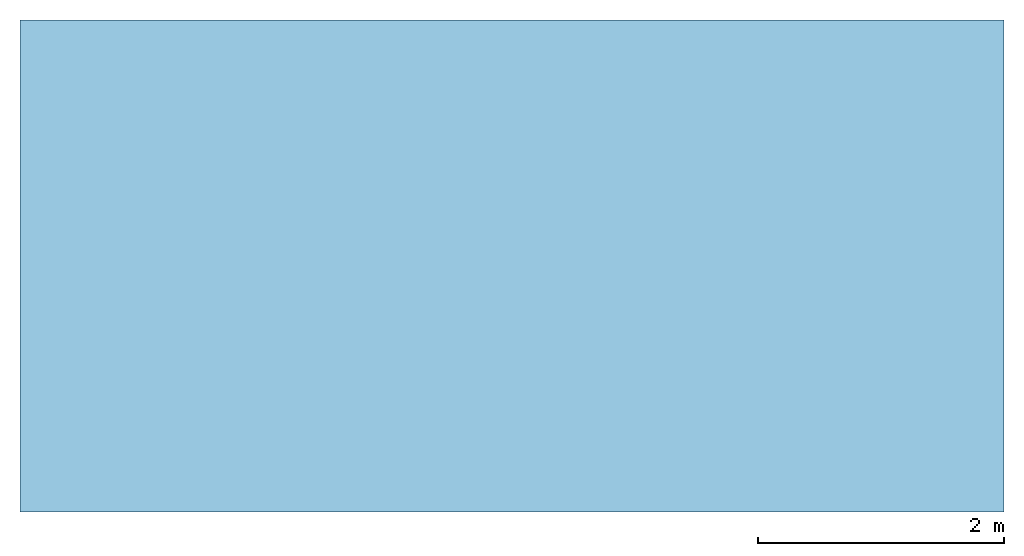
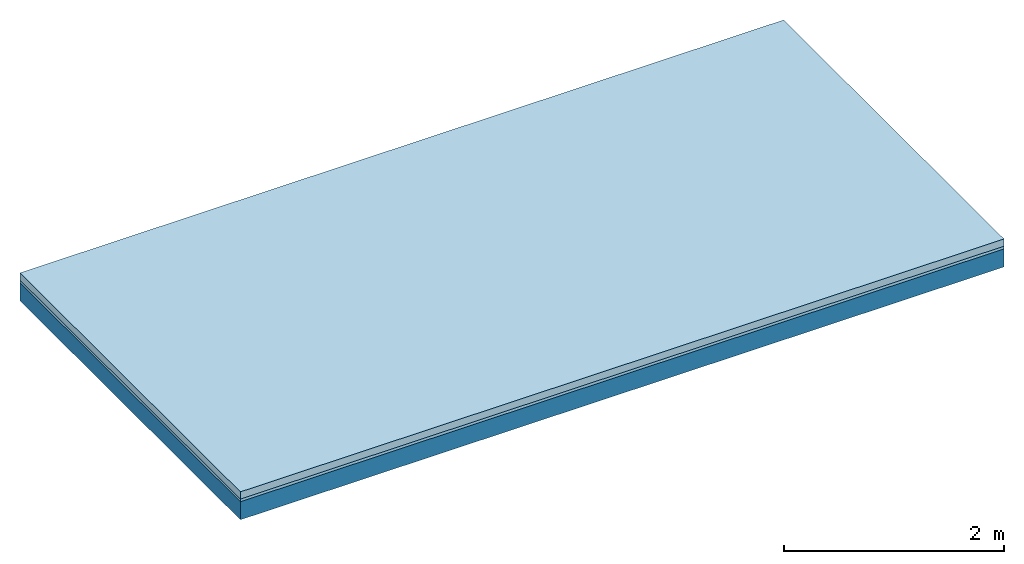
# One storey: 2 plates, 1 member, 1 element without a shape of its own.
"""IFC4 building model written with IfcOpenShell, lengths in metres."""

from ifc_helpers import new_model, si_unit, derived_unit, direction, frame, frame_2d, origin, origin_with_axes, place, context, project, spatial, rectangle, extrude, material, layer, layer_set, type_object, element, aggregate, save


model = new_model("IFC4")

# Units and contexts
plan_context = context("Plan", 3, precision=1e-05, world=origin(), true_north=direction((0.0, 1.0)))
model_context = context("Model", 3, precision=1e-05, world=origin(), true_north=direction((0.0, 1.0)))
ifc_project = project(units=[si_unit("LENGTHUNIT", "METRE"), derived_unit("SOUNDPRESSUREUNIT", [(si_unit("PRESSUREUNIT", "PASCAL", prefix="MICRO"), 0)]), si_unit("ENERGYUNIT", "JOULE", prefix="MEGA"), si_unit("MASSUNIT", "GRAM", prefix="KILO"), derived_unit("THERMALTRANSMITTANCEUNIT", [(si_unit("POWERUNIT", "WATT"), 1), (si_unit("AREAUNIT", "SQUARE_METRE"), -1), (si_unit("THERMODYNAMICTEMPERATUREUNIT", "KELVIN"), -1)]), derived_unit("AREADENSITYUNIT", [(si_unit("MASSUNIT", "GRAM", prefix="KILO"), 1), (si_unit("AREAUNIT", "SQUARE_METRE"), -1)]), derived_unit("USERDEFINED", [(si_unit("ENERGYUNIT", "JOULE", prefix="MEGA"), 1), (si_unit("AREAUNIT", "SQUARE_METRE"), -1)])], contexts=[plan_context, model_context])

# Site, building, storey
site = spatial("IfcSite", under=ifc_project)
building_placement = place(None, origin())
building = spatial("IfcBuilding", under=site, at=building_placement)
storey_placement = place(building_placement, origin())
storey = spatial("IfcBuildingStorey", under=building, at=storey_placement)

# Slab, member, plates
ifc_material_1 = material(Name="Cement screed", Category="04.006")
ifc_layer_1 = layer(ifc_material_1, 0.08, Name="On-material")
ifc_material_2 = material()
ifc_layer_2 = layer(ifc_material_2, 0.03, Name="Impact sound insulation")
ifc_layer_3 = layer(None, 0.2, Name="Supporting structure")
ifc_layer_set = layer_set([ifc_layer_1, ifc_layer_2, ifc_layer_3])
slab_type = type_object("IfcSlabType", Name="A0837", PredefinedType="NOTDEFINED", material=ifc_layer_set)
slab_placement = place(None, frame((0.0, 0.0, 0.0), z_axis=(0.0, 0.0, -1.0), x_axis=(1.0, 0.0, 0.0)))
slab = element("IfcSlab", 1, at=slab_placement, inside=storey, type_object=slab_type, material=ifc_layer_set, Name="Slab #1")
ifc_material_3 = material()
member_placement = place(slab_placement, origin())
member = element("IfcMember", 2, at=member_placement, material=ifc_material_3, Name="Supporting structure", context=plan_context, shape_type="SweptSolid", body=[
    extrude(rectangle(XDim=1.0, YDim=0.2, at=frame_2d((0.5, 0.1), x_axis=(1.0, 0.0))), frame((0.0, 4.0, 0.11), z_axis=(0.0, -1.0, 0.0), x_axis=(1.0, 0.0, 0.0)), (0.0, 0.0, 1.0), 4.0),
    extrude(rectangle(XDim=1.0, YDim=0.2, at=frame_2d((0.5, 0.1), x_axis=(1.0, 0.0))), frame((1.0, 4.0, 0.11), z_axis=(0.0, -1.0, 0.0), x_axis=(1.0, 0.0, 0.0)), (0.0, 0.0, 1.0), 4.0),
    extrude(rectangle(XDim=1.0, YDim=0.2, at=frame_2d((0.5, 0.1), x_axis=(1.0, 0.0))), frame((2.0, 4.0, 0.11), z_axis=(0.0, -1.0, 0.0), x_axis=(1.0, 0.0, 0.0)), (0.0, 0.0, 1.0), 4.0),
    extrude(rectangle(XDim=1.0, YDim=0.2, at=frame_2d((0.5, 0.1), x_axis=(1.0, 0.0))), frame((3.0, 4.0, 0.11), z_axis=(0.0, -1.0, 0.0), x_axis=(1.0, 0.0, 0.0)), (0.0, 0.0, 1.0), 4.0),
    extrude(rectangle(XDim=1.0, YDim=0.2, at=frame_2d((0.5, 0.1), x_axis=(1.0, 0.0))), frame((4.0, 4.0, 0.11), z_axis=(0.0, -1.0, 0.0), x_axis=(1.0, 0.0, 0.0)), (0.0, 0.0, 1.0), 4.0),
    extrude(rectangle(XDim=1.0, YDim=0.2, at=frame_2d((0.5, 0.1), x_axis=(1.0, 0.0))), frame((5.0, 4.0, 0.11), z_axis=(0.0, -1.0, 0.0), x_axis=(1.0, 0.0, 0.0)), (0.0, 0.0, 1.0), 4.0),
    extrude(rectangle(XDim=1.0, YDim=0.2, at=frame_2d((0.5, 0.1), x_axis=(1.0, 0.0))), frame((6.0, 4.0, 0.11), z_axis=(0.0, -1.0, 0.0), x_axis=(1.0, 0.0, 0.0)), (0.0, 0.0, 1.0), 4.0),
    extrude(rectangle(XDim=1.0, YDim=0.2, at=frame_2d((0.5, 0.1), x_axis=(1.0, 0.0))), frame((7.0, 4.0, 0.11), z_axis=(0.0, -1.0, 0.0), x_axis=(1.0, 0.0, 0.0)), (0.0, 0.0, 1.0), 4.0),
])
plate_1_placement = place(slab_placement, origin())
plate_1 = element("IfcPlate", 3, at=plate_1_placement, material=ifc_material_1, Name="On-material", context=plan_context, shape_type="SweptSolid", body=[
    extrude(rectangle(XDim=8.0, YDim=4.0, at=frame_2d((4.0, 2.0), x_axis=(1.0, 0.0))), origin_with_axes(), (0.0, 0.0, 1.0), 0.08),
])
plate_2_placement = place(slab_placement, origin())
plate_2 = element("IfcPlate", 4, at=plate_2_placement, material=ifc_material_2, Name="Impact sound insulation", context=plan_context, shape_type="SweptSolid", body=[
    extrude(rectangle(XDim=8.0, YDim=4.0, at=frame_2d((4.0, 2.0), x_axis=(1.0, 0.0))), frame((0.0, 0.0, 0.08), z_axis=(0.0, 0.0, 1.0), x_axis=(1.0, 0.0, 0.0)), (0.0, 0.0, 1.0), 0.03),
])
aggregate(slab, [plate_1, plate_2, member])

save(model, "model.ifc")
